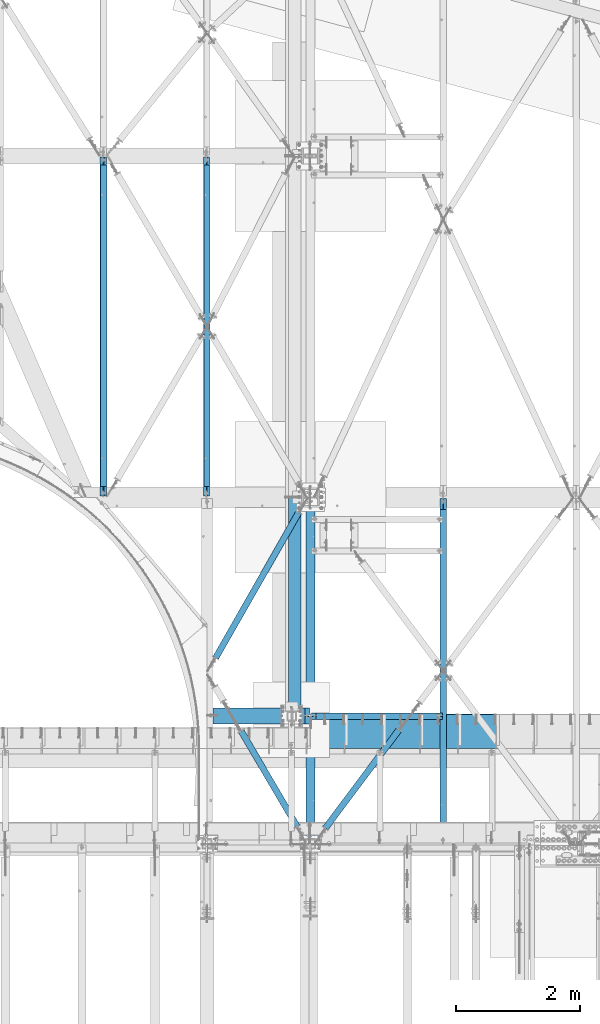
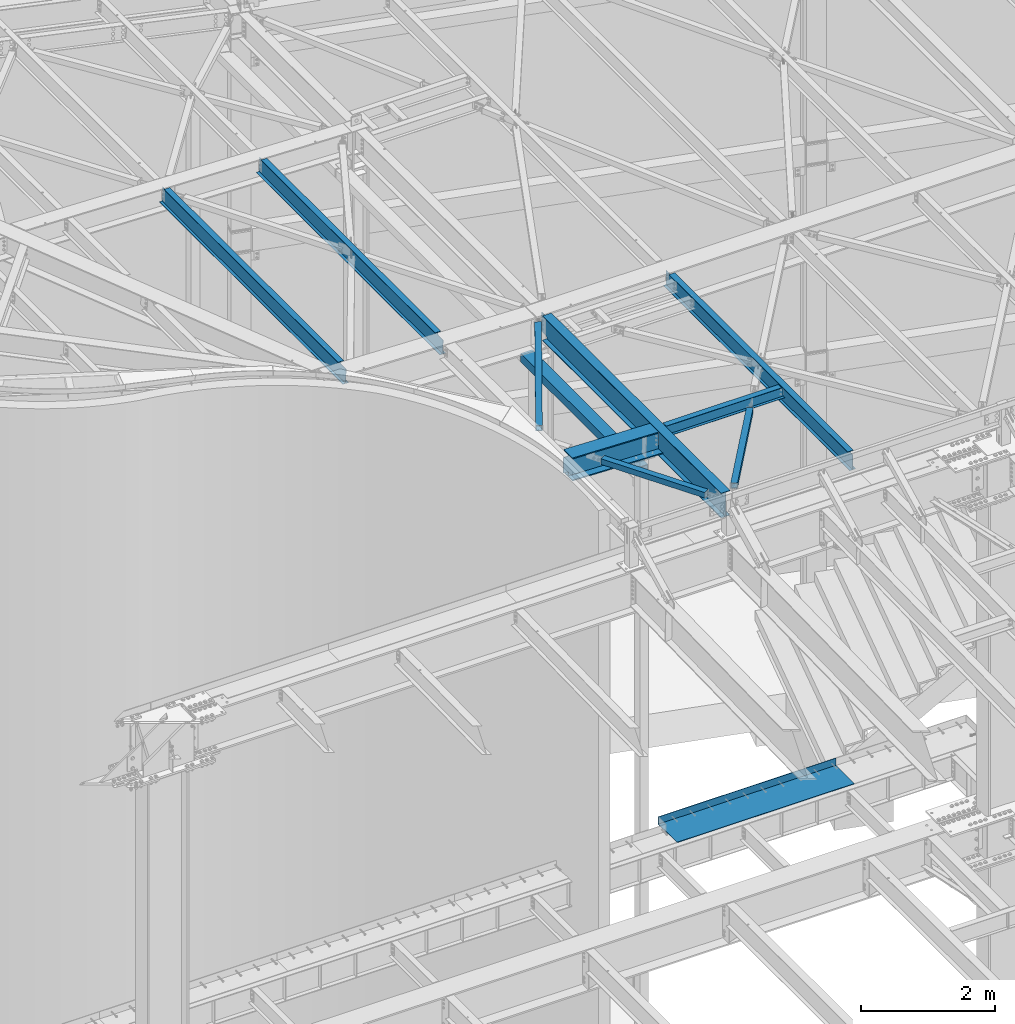
# One storey, part 1150 of 1763: 11 beams, 11 elements without a shape of their own.
"""IFC2X3 building model written with IfcOpenShell, lengths in millimetres."""

from ifc_helpers import new_model, si_unit, frame, origin_with_axes, place, context, subcontext, project, spatial, faceted_brep, material, type_object, element, aggregate, save


model = new_model("IFC2X3")

# Units and contexts
model_context = context("Model", 3, precision=1e-05, world=origin_with_axes())
body_context = subcontext(model_context, "Body", "Model", "MODEL_VIEW")
ifc_project = project(units=[si_unit("LENGTHUNIT", "METRE", prefix="MILLI"), si_unit("AREAUNIT", "SQUARE_METRE"), si_unit("VOLUMEUNIT", "CUBIC_METRE"), si_unit("MASSUNIT", "GRAM", prefix="KILO"), si_unit("TIMEUNIT", "SECOND"), si_unit("PLANEANGLEUNIT", "RADIAN"), si_unit("SOLIDANGLEUNIT", "STERADIAN"), si_unit("THERMODYNAMICTEMPERATUREUNIT", "DEGREE_CELSIUS"), si_unit("LUMINOUSINTENSITYUNIT", "LUMEN")], contexts=[model_context])

# Site, building, storey
site_placement = place(None, origin_with_axes())
site = spatial("IfcSite", under=ifc_project, at=site_placement, CompositionType="ELEMENT")
building_placement = place(site_placement, origin_with_axes())
building = spatial("IfcBuilding", under=site, at=building_placement, Name="Undefined", CompositionType="ELEMENT")
storey_placement = place(building_placement, origin_with_axes())
storey = spatial("IfcBuildingStorey", under=building, at=storey_placement, Name="Undefined", CompositionType="ELEMENT", Elevation=0.0)

# Assembly, beam
assembly_1_placement = place(storey_placement, origin_with_axes())
assembly_1 = element("IfcElementAssembly", 1, at=assembly_1_placement, inside=storey, Name="BEAM", AssemblyPlace="NOTDEFINED", PredefinedType="RIGID_FRAME")
ifc_material_1 = material(Name="STEEL/A992")
beam_type_1 = type_object("IfcBeamType", Name="W8X10", PredefinedType="NOTDEFINED")
beam_1_placement = place(assembly_1_placement, frame((-39672.2896175026, 54178.1999999993, 12345.9875), z_axis=(0.0, 0.0, 1.0), x_axis=(1.0, 0.0, 0.0)))
beam_1 = element("IfcBeam", 2, at=beam_1_placement, type_object=beam_type_1, material=ifc_material_1, Name="BEAM", ObjectType="W8X10", context=body_context, shape_type="Brep", body=[
    faceted_brep([(16.6687500075204, -2.38124999999854, -95.25), (16.6687500075204, -50.8000000000029, -95.25), (2124.075, -50.8000000000029, -95.25), (2124.075, -2.38124999999854, -95.25), (16.6687500075204, -50.8000000000029, -100.012500000001), (2124.075, -50.8000000000029, -100.012500000001), (16.6687500075204, 50.8000000000029, -100.012500000001), (2124.075, 50.8000000000029, -100.012500000001), (16.6687500075204, 50.8000000000029, -95.25), (2124.075, 50.8000000000029, -95.25), (2073.27499999999, -50.8000000000029, 100.012500000001), (2073.27499999999, -50.8000000000029, 95.25), (2073.27499999999, -2.38124999999854, 95.25), (2073.27499999999, -2.38124999999854, 93.4024995803829), (2073.27499999999, 2.38124999999854, 93.4024995803829), (2073.27499999999, 2.38124999999854, 95.25), (2073.27499999999, 50.8000000000029, 95.25), (2073.27499999999, 50.8000000000029, 100.012500000001), (2074.24172992259, -2.38124999999854, 88.5424200623365), (2074.24172992259, 2.38124999999854, 88.5424200623365), (2076.99474382306, -2.38124999999854, 84.4222435941829), (2076.99474382306, 2.38124999999854, 84.4222435941829), (2081.11492029121, -2.38124999999854, 81.6692296937053), (2081.11492029121, 2.38124999999854, 81.6692296937053), (2085.97499980926, -2.38124999999854, 80.7024997711178), (2085.97499980926, 2.38124999999854, 80.7024997711178), (2124.075, -2.38124999999854, 80.7024997711178), (2124.075, 2.38124999999854, 80.7024997711178), (2124.075, 2.38124999999854, -95.25), (16.6687500075204, 2.38124999999854, -95.25), (81.0600766645366, -2.38124999999854, 72.4042299225875), (81.0600766645366, 2.38124999999854, 72.4042299225875), (76.1999971464902, 2.38124999999854, 71.4375), (76.1999971464902, -2.38124999999854, 71.4375), (85.1802531326903, -2.38124999999854, 75.1572438230651), (85.1802531326903, 2.38124999999854, 75.1572438230651), (87.9332670331642, -2.38124999999854, 79.2774202912187), (87.9332670331642, 2.38124999999854, 79.2774202912187), (88.8999969557553, -2.38124999999854, 84.1374998092651), (88.8999969557553, 2.38124999999854, 84.1374998092651), (16.6687500075204, 2.38124999999854, 71.4375), (88.8999969557553, 2.38124999999854, 95.25), (88.8999969557553, 50.8000000000029, 95.25), (88.8999969557553, 50.8000000000029, 100.012500000001), (88.8999969557553, -50.8000000000029, 100.012500000001), (88.8999969557553, -50.8000000000029, 95.25), (88.8999969557553, -2.38124999999854, 95.25), (16.6687500075204, -2.38124999999854, 71.4375)], [[[0, 1, 2, 3]], [[1, 4, 5, 2]], [[4, 6, 7, 5]], [[6, 8, 9, 7]], [[10, 11, 12, 13, 14, 15, 16, 17]], [[18, 19, 14, 13]], [[20, 21, 19, 18]], [[22, 23, 21, 20]], [[24, 25, 23, 22]], [[26, 27, 25, 24]], [[3, 2, 5, 7, 9, 28, 27, 26]], [[8, 29, 28, 9]], [[30, 31, 32, 33]], [[34, 35, 31, 30]], [[36, 37, 35, 34]], [[38, 39, 37, 36]], [[28, 29, 40, 32, 31, 35, 37, 39, 41, 15, 14, 19, 21, 23, 25, 27]], [[41, 42, 16, 15]], [[42, 43, 17, 16]], [[43, 44, 10, 17]], [[44, 45, 11, 10]], [[45, 46, 12, 11]], [[44, 43, 42, 41, 39, 38, 46, 45]], [[22, 20, 18, 13, 12, 46, 38, 36, 34, 30, 33, 47, 0, 3, 26, 24]], [[29, 8, 6, 4, 1, 0, 47, 40]], [[33, 32, 40, 47]]]),
])
aggregate(assembly_1, [beam_1])

assembly_2_placement = place(storey_placement, origin_with_axes())
assembly_2 = element("IfcElementAssembly", 3, at=assembly_2_placement, inside=storey, Name="H. BRACE", AssemblyPlace="NOTDEFINED", PredefinedType="RIGID_FRAME")
ifc_material_2 = material()
beam_type_2 = type_object("IfcBeamType", Name="HSS4X4X3/8", PredefinedType="NOTDEFINED")
beam_2_placement = place(assembly_2_placement, frame((-38124.1466139279, 54121.0499999993, 12371.3875), z_axis=(0.0, 0.0, 1.0), x_axis=(-0.599271154042197, -0.800546116056367, 0.0)))
beam_2 = element("IfcBeam", 4, at=beam_2_placement, type_object=beam_type_2, material=ifc_material_2, Name="H. BRACE", ObjectType="HSS4X4X3/8", context=body_context, shape_type="Brep", body=[
    faceted_brep([(207.817612758732, 41.2749999996595, -41.2749999999996), (207.817612758732, -41.2750000005763, -41.2749999999996), (2179.99701835294, -41.2750000049418, -41.2749999999996), (2179.99701835295, 41.2749999952939, -41.2749999999996), (207.817612758732, -41.2750000005763, 41.2749999999996), (2179.99701835294, -41.2750000049418, 41.2749999999996), (207.817612758732, 41.2749999996595, 41.2749999999996), (2179.99701835295, 41.2749999952939, 41.2749999999996), (207.817612758736, 50.7999999996828, -50.7999999999993), (207.817612758736, 50.7999999996828, 50.7999999999993), (2179.99701835294, 50.7999999953317, 50.7999999999993), (2179.99701835294, 50.7999999953317, -50.7999999999993), (207.817612758729, -50.8000000005995, 50.7999999999993), (2179.99701835294, -50.8000000049651, 50.7999999999993), (207.817612758729, -50.8000000005995, -50.7999999999993), (2179.99701835294, -50.8000000049651, -50.7999999999993)], [[[0, 1, 2, 3]], [[1, 4, 5, 2]], [[4, 6, 7, 5]], [[6, 0, 3, 7]], [[8, 9, 10, 11]], [[9, 12, 13, 10]], [[12, 14, 15, 13]], [[14, 8, 11, 15]], [[13, 15, 11, 10], [5, 7, 3, 2]], [[14, 12, 9, 8], [6, 4, 1, 0]]]),
])
aggregate(assembly_2, [beam_2])

assembly_3_placement = place(storey_placement, origin_with_axes())
assembly_3 = element("IfcElementAssembly", 5, at=assembly_3_placement, inside=storey, Name="H. BRACE", AssemblyPlace="NOTDEFINED", PredefinedType="RIGID_FRAME")
beam_3_placement = place(assembly_3_placement, frame((-39723.0896174477, 52120.7999999996, 12371.3874999998), z_axis=(0.0, 0.0, 1.0), x_axis=(-0.506135019889158, 0.862454254811118, 0.0)))
beam_3 = element("IfcBeam", 6, at=beam_3_placement, type_object=beam_type_2, material=ifc_material_2, Name="H. BRACE", ObjectType="HSS4X4X3/8", context=body_context, shape_type="Brep", body=[
    faceted_brep([(326.409237413129, 41.2749999995231, -41.2749999999996), (326.409237413136, -41.2750000006035, -41.2749999999996), (2102.46857836019, -41.2750000035321, -41.2749999999996), (2102.46857836324, 41.2749999965836, -41.2749999999996), (326.409237413136, -41.2750000006035, 41.2749999999996), (2102.46857837139, -41.2750000035321, 41.2749999999996), (326.409237413129, 41.2749999995231, 41.2749999999996), (2102.46857837446, 41.2749999965836, 41.2749999999996), (326.409237413136, 50.7999999995282, -50.7999999999993), (326.409237413136, 50.7999999995282, 50.7999999999993), (2102.46857837609, 50.7999999965996, 50.7999999999993), (2102.46857836231, 50.7999999965996, -50.7999999999993), (326.409237413129, -50.8000000006086, 50.7999999999993), (2102.46857837234, -50.8000000035518, 50.7999999999993), (326.409237413129, -50.8000000006086, -50.7999999999993), (2102.46857835854, -50.8000000035518, -50.7999999999993)], [[[0, 1, 2, 3]], [[1, 4, 5, 2]], [[4, 6, 7, 5]], [[6, 0, 3, 7]], [[8, 9, 10, 11]], [[9, 12, 13, 10]], [[12, 14, 15, 13]], [[14, 8, 11, 15]], [[13, 15, 11, 10], [5, 7, 3, 2]], [[14, 12, 9, 8], [6, 4, 1, 0]]]),
])
aggregate(assembly_3, [beam_3])

assembly_4_placement = place(storey_placement, origin_with_axes())
assembly_4 = element("IfcElementAssembly", 7, at=assembly_4_placement, inside=storey, Name="H. BRACE", AssemblyPlace="NOTDEFINED", PredefinedType="RIGID_FRAME")
beam_4_placement = place(assembly_4_placement, frame((-39723.089617434, 57702.4500000121, 12371.3875), z_axis=(0.0, 0.0, 1.0), x_axis=(-0.495889007142934, -0.868385912250305, 0.0)))
beam_4 = element("IfcBeam", 8, at=beam_4_placement, type_object=beam_type_2, material=ifc_material_2, Name="H. BRACE", ObjectType="HSS4X4X3/8", context=body_context, shape_type="Brep", body=[
    faceted_brep([(285.423960958, 41.2750000006272, -41.2749999999996), (285.423960958004, -41.2749999996304, -41.2749999999996), (2975.4343394475, -41.2749999949665, -41.2749999999996), (2975.4343394475, 41.2750000052838, -41.2749999999996), (285.423960958004, -41.2749999996304, 41.2749999999996), (2975.4343394475, -41.2749999949665, 41.2749999999996), (285.423960958, 41.2750000006272, 41.2749999999996), (2975.4343394475, 41.2750000052838, 41.2749999999996), (285.423960958007, 50.8000000006505, -50.7999999999993), (285.423960958007, 50.8000000006505, 50.7999999999993), (2975.43433944751, 50.8000000053216, 50.7999999999993), (2975.43433944751, 50.8000000053216, -50.7999999999993), (285.423960958004, -50.7999999996609, 50.7999999999993), (2975.43433944751, -50.7999999950043, 50.7999999999993), (285.423960958004, -50.7999999996609, -50.7999999999993), (2975.43433944751, -50.7999999950043, -50.7999999999993)], [[[0, 1, 2, 3]], [[1, 4, 5, 2]], [[4, 6, 7, 5]], [[6, 0, 3, 7]], [[8, 9, 10, 11]], [[9, 12, 13, 10]], [[12, 14, 15, 13]], [[14, 8, 11, 15]], [[13, 15, 11, 10], [5, 7, 3, 2]], [[14, 12, 9, 8], [6, 4, 1, 0]]]),
])
aggregate(assembly_4, [beam_4])

assembly_5_placement = place(storey_placement, origin_with_axes())
assembly_5 = element("IfcElementAssembly", 9, at=assembly_5_placement, inside=storey, Name="BEAM", AssemblyPlace="NOTDEFINED", PredefinedType="RIGID_FRAME")
ifc_material_3 = material(Name="STEEL/A36")
beam_type_3 = type_object("IfcBeamType", PredefinedType="NOTDEFINED")
beam_5_placement = place(assembly_5_placement, frame((-38148.2896174484, 53657.5, 5199.0625), z_axis=(1.0, 0.0, 0.0), x_axis=(0.0, 1.0, 0.0)))
beam_5 = element("IfcBeam", 10, at=beam_5_placement, type_object=beam_type_3, material=ifc_material_3, Name="BENT PLATE", context=body_context, shape_type="Brep", body=[
    faceted_brep([(0.0, -4.76249999999982, -1524.0), (0.0, -4.76249999999982, 1524.0), (0.0, 4.76249999999982, 1524.0), (0.0, 4.76249999999982, -1524.0), (546.100000000006, 4.76249999999982, 1524.0), (546.100000000006, 4.76249999999982, -1524.0), (555.625, -4.76249999999982, -1524.0), (555.625, -4.76249999999982, 1524.0), (546.100000000006, 134.937496948242, 1524.0), (546.100000000006, 134.937496948242, -1524.0), (555.625, 134.937496948242, 1524.0), (555.625, 134.937496948242, -1524.0)], [[[0, 1, 2, 3]], [[3, 2, 4, 5]], [[1, 0, 6, 7]], [[5, 4, 8, 9]], [[4, 2, 1, 7, 10, 8]], [[7, 6, 11, 10]], [[6, 0, 3, 5, 9, 11]], [[10, 11, 9, 8]]]),
])
aggregate(assembly_5, [beam_5])

assembly_6_placement = place(storey_placement, origin_with_axes())
assembly_6 = element("IfcElementAssembly", 11, at=assembly_6_placement, inside=storey, Name="BEAM", AssemblyPlace="NOTDEFINED", PredefinedType="RIGID_FRAME")
beam_type_4 = type_object("IfcBeamType", Name="W12X16", PredefinedType="NOTDEFINED")
beam_6_placement = place(assembly_6_placement, frame((-43008.8652893648, 57702.45, 12391.7005364318), z_axis=(0.0294363099980619, 0.0, 0.999566657934176), x_axis=(0.0, 1.0, 0.0)))
beam_6 = element("IfcBeam", 12, at=beam_6_placement, type_object=beam_type_4, material=ifc_material_1, Name="BEAM", ObjectType="W12X16", context=body_context, shape_type="Brep", body=[
    faceted_brep([(20.637499999335, -3.17500000023574, -146.050000000019), (20.637499999335, -50.8000000002503, -146.05000000003), (5480.84374999933, -50.8000000002503, -146.05000000003), (5480.84374999933, -3.17500000023574, -146.050000000019), (20.637499999335, -50.8000000002576, -152.400000000032), (5480.84374999933, -50.8000000002576, -152.400000000032), (20.637499999335, 50.7999999997701, -152.400000000003), (5480.84374999933, 50.7999999997701, -152.400000000003), (20.637499999335, 50.7999999997774, -146.050000000005), (5480.84374999933, 50.7999999997774, -146.050000000005), (5356.22500610327, -50.7999999997846, 152.400000000001), (5356.22500610327, -50.7999999997919, 146.050000000003), (5356.22500610327, -3.17499999978463, 146.050000000016), (5356.22500610327, -3.17499999981374, 125.285104586563), (5356.22500610327, 3.17500000018481, 125.285104586579), (5356.22500610327, 3.17500000022119, 146.050000000017), (5356.22500610327, 50.8000000002285, 146.05000000003), (5356.22500610327, 50.8000000002357, 152.400000000032), (5357.19173602586, -3.17499999982101, 120.425025068516), (5357.19173602586, 3.17500000017753, 120.425025068527), (5359.94474992633, -3.17499999982829, 116.304848600361), (5359.94474992633, 3.17500000017026, 116.304848600375), (5364.06492639449, -3.17499999983556, 113.551834699883), (5364.06492639449, 3.17500000016298, 113.551834699894), (5368.92500591253, -3.17499999983556, 112.585104777294), (5368.92500591253, 3.17500000016298, 112.585104777307), (5480.84374999933, -3.17499999983556, 112.585104777085), (5480.84374999933, 3.17500000016298, 112.585104777076), (5480.84374999933, 3.17499999977008, -146.050000000016), (20.637499999335, 3.17499999977008, -146.050000000016), (168.372576656366, -3.17499999985012, 103.511779606619), (168.372576656366, 3.17500000014843, 103.511779606633), (163.512497138319, 3.17500000014843, 102.545049684046), (163.512497138319, -3.17499999985012, 102.545049684031), (172.492753124519, -3.17499999985012, 106.2647935071), (172.492753124519, 3.17500000015571, 106.264793507111), (175.245767024993, -3.17499999983556, 110.384969975255), (175.245767024993, 3.17500000016298, 110.384969975266), (176.212496947584, -3.17499999982829, 115.245049493302), (176.212496947584, 3.17500000017026, 115.245049493313), (20.637499999335, 3.17500000014843, 102.545049684255), (176.212496947584, 3.17500000022119, 146.050000000017), (176.212496947584, 50.8000000002285, 146.05000000003), (176.212496947584, 50.8000000002357, 152.400000000032), (176.212496947584, -50.7999999997846, 152.400000000001), (176.212496947584, -50.7999999997919, 146.050000000003), (176.212496947584, -3.17499999978463, 146.050000000016), (20.637499999335, -3.17499999985012, 102.545049684262)], [[[0, 1, 2, 3]], [[1, 4, 5, 2]], [[4, 6, 7, 5]], [[6, 8, 9, 7]], [[10, 11, 12, 13, 14, 15, 16, 17]], [[18, 19, 14, 13]], [[20, 21, 19, 18]], [[22, 23, 21, 20]], [[24, 25, 23, 22]], [[26, 27, 25, 24]], [[3, 2, 5, 7, 9, 28, 27, 26]], [[8, 29, 28, 9]], [[30, 31, 32, 33]], [[34, 35, 31, 30]], [[36, 37, 35, 34]], [[38, 39, 37, 36]], [[15, 14, 19, 21, 23, 25, 27, 28, 29, 40, 32, 31, 35, 37, 39, 41]], [[16, 15, 41, 42]], [[17, 16, 42, 43]], [[10, 17, 43, 44]], [[11, 10, 44, 45]], [[12, 11, 45, 46]], [[44, 43, 42, 41, 39, 38, 46, 45]], [[36, 34, 30, 33, 47, 0, 3, 26, 24, 22, 20, 18, 13, 12, 46, 38]], [[29, 8, 6, 4, 1, 0, 47, 40]], [[33, 32, 40, 47]]]),
])
aggregate(assembly_6, [beam_6])

assembly_7_placement = place(storey_placement, origin_with_axes())
assembly_7 = element("IfcElementAssembly", 13, at=assembly_7_placement, inside=storey, Name="BEAM", AssemblyPlace="NOTDEFINED", PredefinedType="RIGID_FRAME")
beam_7_placement = place(assembly_7_placement, frame((-41343.024315424, 57702.4500000225, 12342.6801043308), z_axis=(0.0294363099980619, 0.0, 0.999566657934176), x_axis=(0.0, 1.0, 0.0)))
beam_7 = element("IfcBeam", 14, at=beam_7_placement, type_object=beam_type_4, material=ifc_material_1, Name="BEAM", ObjectType="W12X16", context=body_context, shape_type="Brep", body=[
    faceted_brep([(20.637499999335, -3.17500000023574, -146.050000000019), (20.637499999335, -50.8000000002503, -146.05000000003), (5480.84374999933, -50.8000000002503, -146.05000000003), (5480.84374999933, -3.17500000023574, -146.050000000019), (20.637499999335, -50.8000000002576, -152.400000000032), (5480.84374999933, -50.8000000002576, -152.400000000032), (20.637499999335, 50.7999999997701, -152.400000000003), (5480.84374999933, 50.7999999997701, -152.400000000003), (20.637499999335, 50.7999999997774, -146.050000000005), (5480.84374999933, 50.7999999997774, -146.050000000005), (5356.22500610327, -50.7999999997846, 152.400000000001), (5356.22500610327, -50.7999999997919, 146.050000000003), (5356.22500610327, -3.17499999978463, 146.050000000016), (5356.22500608081, -3.17499999981374, 122.97482751928), (5356.22500608081, 3.17500000018481, 122.974827519292), (5356.22500610327, 3.17500000022119, 146.050000000017), (5356.22500610327, 50.8000000002285, 146.05000000003), (5356.22500610327, 50.8000000002357, 152.400000000032), (5357.1917360034, -3.17499999982101, 118.114748001233), (5357.1917360034, 3.17500000017753, 118.114748001244), (5359.94474990387, -3.17499999982829, 113.994571533076), (5359.94474990387, 3.17500000017753, 113.994571533092), (5364.06492637203, -3.17499999983556, 111.241557632598), (5364.06492637203, 3.17500000017026, 111.241557632609), (5368.92500589007, -3.17499999983556, 110.274827710011), (5368.92500589007, 3.17500000016298, 110.274827710022), (5480.84374997687, -3.17499999983556, 110.274827709802), (5480.84374997687, 3.17500000016298, 110.274827709791), (5480.84374999933, 3.17499999977008, -146.050000000016), (20.637499999335, 3.17499999977008, -146.050000000016), (168.372576633905, -3.17499999985012, 101.258135918861), (168.372576633905, 3.17500000014843, 101.258135918875), (163.512497115858, 3.17500000014843, 100.291405996286), (163.512497115858, -3.17499999985012, 100.291405996273), (172.492753102058, -3.17499999984284, 104.01114981934), (172.492753102058, 3.17500000015571, 104.011149819355), (175.245767002532, -3.17499999983556, 108.131326287496), (175.245767002532, 3.17500000016298, 108.131326287508), (176.212496925124, -3.17499999983556, 112.991405805542), (176.212496925124, 3.17500000017753, 112.991405805555), (20.6374999768741, 3.17500000014843, 100.291405996495), (176.212496947584, 3.17500000022119, 146.050000000017), (176.212496947584, 50.8000000002285, 146.05000000003), (176.212496947584, 50.8000000002357, 152.400000000032), (176.212496947584, -50.7999999997846, 152.400000000001), (176.212496947584, -50.7999999997919, 146.050000000003), (176.212496947584, -3.17499999978463, 146.050000000016), (20.6374999768741, -3.17499999985012, 100.291405996506)], [[[0, 1, 2, 3]], [[1, 4, 5, 2]], [[4, 6, 7, 5]], [[6, 8, 9, 7]], [[10, 11, 12, 13, 14, 15, 16, 17]], [[18, 19, 14, 13]], [[20, 21, 19, 18]], [[22, 23, 21, 20]], [[24, 25, 23, 22]], [[26, 27, 25, 24]], [[3, 2, 5, 7, 9, 28, 27, 26]], [[8, 29, 28, 9]], [[30, 31, 32, 33]], [[34, 35, 31, 30]], [[36, 37, 35, 34]], [[38, 39, 37, 36]], [[15, 14, 19, 21, 23, 25, 27, 28, 29, 40, 32, 31, 35, 37, 39, 41]], [[16, 15, 41, 42]], [[17, 16, 42, 43]], [[10, 17, 43, 44]], [[11, 10, 44, 45]], [[12, 11, 45, 46]], [[44, 43, 42, 41, 39, 38, 46, 45]], [[36, 34, 30, 33, 47, 0, 3, 26, 24, 22, 20, 18, 13, 12, 46, 38]], [[29, 8, 6, 4, 1, 0, 47, 40]], [[33, 32, 40, 47]]]),
])
aggregate(assembly_7, [beam_7])

assembly_8_placement = place(storey_placement, origin_with_axes())
assembly_8 = element("IfcElementAssembly", 15, at=assembly_8_placement, inside=storey, Name="BEAM", AssemblyPlace="NOTDEFINED", PredefinedType="RIGID_FRAME")
beam_8_placement = place(assembly_8_placement, frame((-37532.3396174484, 52120.8, 12293.6), z_axis=(0.0, 0.0, 1.0), x_axis=(0.0, 1.0, 0.0)))
beam_8 = element("IfcBeam", 16, at=beam_8_placement, type_object=beam_type_4, material=ifc_material_1, Name="BEAM", ObjectType="W12X16", context=body_context, shape_type="Brep", body=[
    faceted_brep([(63.5000001907174, -3.17499999999927, 126.740001678467), (63.5000001907174, 3.17499999999927, 126.740001678467), (15.8749999999854, 3.17499999999927, 126.740001678467), (15.8749999999854, -3.17499999999927, 126.740001678467), (68.3600797087638, -3.17499999999927, 127.706731601054), (68.3600797087638, 3.17499999999927, 127.706731601054), (72.4802561769175, -3.17499999999927, 130.459745501532), (72.4802561769175, 3.17499999999927, 130.459745501532), (75.2332700773914, -3.17499999999927, 134.579921969686), (75.2332700773914, 3.17499999999927, 134.579921969686), (76.1999999999825, -3.17499999999927, 139.440001487732), (76.1999999999825, 3.17499999999927, 139.440001487732), (76.1999999999825, -50.7999999999993, 152.4), (76.1999999999825, 50.7999999999993, 152.4), (76.1999999999825, 50.7999999999993, 146.049999999999), (76.1999999999825, 3.17499999999927, 146.049999999999), (76.1999999999825, -3.17499999999927, 146.049999999999), (76.1999999999825, -50.7999999999993, 146.049999999999), (15.8749999999854, -3.17499999999927, -146.049999999999), (15.8749999999854, -50.7999999999993, -146.049999999999), (5561.01249999999, -50.7999999999993, -146.049999999999), (5561.01249999999, -3.17499999999927, -146.049999999999), (15.8749999999854, -50.7999999999993, -152.4), (5561.01249999999, -50.7999999999993, -152.4), (15.8749999999854, 50.7999999999993, -152.4), (5561.01249999999, 50.7999999999993, -152.4), (15.8749999999854, 50.7999999999993, -146.049999999999), (5561.01249999999, 50.7999999999993, -146.049999999999), (15.8749999999854, 3.17499999999927, -146.049999999999), (5561.01249999999, 3.17499999999927, -146.049999999999), (5561.01249999999, 3.17499999999927, 114.040001678466), (5561.01249999999, -3.17499999999927, 114.040001678466), (5402.26249980926, 3.17499999999927, 114.040001678466), (5402.26249980926, -3.17499999999927, 114.040001678466), (5397.40242029121, 3.17499999999927, 115.006731601054), (5397.40242029121, -3.17499999999927, 115.006731601054), (5393.28224382306, 3.17499999999927, 117.759745501531), (5393.28224382306, -3.17499999999927, 117.759745501531), (5390.52922992258, 3.17499999999927, 121.879921969685), (5390.52922992258, -3.17499999999927, 121.879921969685), (5389.56249999999, 3.17499999999927, 126.740001487731), (5389.56249999999, -3.17499999999927, 126.740001487731), (5389.56249999999, -50.7999999999993, 152.4), (5389.56249999999, -50.7999999999993, 146.049999999999), (5389.56249999999, -3.17499999999927, 146.049999999999), (5389.56249999999, 3.17499999999927, 146.049999999999), (5389.56249999999, 50.7999999999993, 146.049999999999), (5389.56249999999, 50.7999999999993, 152.4)], [[[0, 1, 2, 3]], [[4, 5, 1, 0]], [[6, 7, 5, 4]], [[8, 9, 7, 6]], [[10, 11, 9, 8]], [[12, 13, 14, 15, 11, 10, 16, 17]], [[18, 19, 20, 21]], [[19, 22, 23, 20]], [[22, 24, 25, 23]], [[24, 26, 27, 25]], [[26, 28, 29, 27]], [[21, 20, 23, 25, 27, 29, 30, 31]], [[31, 30, 32, 33]], [[33, 32, 34, 35]], [[35, 34, 36, 37]], [[37, 36, 38, 39]], [[39, 38, 40, 41]], [[42, 43, 44, 41, 40, 45, 46, 47]], [[43, 42, 12, 17]], [[44, 43, 17, 16]], [[8, 6, 4, 0, 3, 18, 21, 31, 33, 35, 37, 39, 41, 44, 16, 10]], [[28, 26, 24, 22, 19, 18, 3, 2]], [[45, 40, 38, 36, 34, 32, 30, 29, 28, 2, 1, 5, 7, 9, 11, 15]], [[46, 45, 15, 14]], [[47, 46, 14, 13]], [[42, 47, 13, 12]]]),
])
aggregate(assembly_8, [beam_8])

assembly_9_placement = place(storey_placement, origin_with_axes())
assembly_9 = element("IfcElementAssembly", 17, at=assembly_9_placement, inside=storey, Name="BEAM", AssemblyPlace="NOTDEFINED", PredefinedType="RIGID_FRAME")
beam_type_5 = type_object("IfcBeamType", Name="W18X35", PredefinedType="NOTDEFINED")
beam_9_placement = place(assembly_9_placement, frame((-39672.2896174408, 52044.6000000031, 12220.575), z_axis=(0.0, 0.0, 1.0), x_axis=(0.0, 1.0, 0.0)))
beam_9 = element("IfcBeam", 18, at=beam_9_placement, type_object=beam_type_5, material=ifc_material_1, Name="BEAM", ObjectType="W18X35", context=body_context, shape_type="Brep", body=[
    faceted_brep([(5637.2124999969, -3.96875, 174.365001678467), (5637.2124999969, 3.96875, 174.365001678467), (5491.16249980615, 3.96875, 174.365001678467), (5491.16249980615, -3.96875, 174.365001678467), (5486.3024202881, 3.96875, 175.331731601054), (5486.3024202881, -3.96875, 175.331731601054), (5482.18224381995, 3.96875, 178.084745501532), (5482.18224381995, -3.96875, 178.084745501532), (5479.42922991946, 3.96875, 182.204921969686), (5479.42922991946, -3.96875, 182.204921969686), (5478.46249999688, 3.96875, 187.065001487732), (5478.46249999688, -3.96875, 187.065001487732), (165.09999999791, -76.1999999999971, 214.3125), (165.09999999791, -3.96875, 214.3125), (5478.46249999688, -3.96875, 214.3125), (5478.46249999688, -76.1999999999971, 214.3125), (165.09999999791, -76.1999999999971, 225.424999999999), (5478.46249999688, -76.1999999999971, 225.424999999999), (165.09999999791, 76.1999999999971, 225.424999999999), (5478.46249999688, 76.1999999999971, 225.424999999999), (165.09999999791, 76.1999999999971, 214.3125), (5478.46249999688, 76.1999999999971, 214.3125), (5478.46249999688, 3.96875, 214.3125), (165.09999999791, 3.96875, 214.3125), (165.09999999791, -76.1999999999971, -225.424999999999), (165.09999999791, -76.1999999999971, -214.3125), (165.09999999791, -3.96875, -214.3125), (165.09999999791, 3.96875, -214.3125), (165.09999999791, 76.1999999999971, -214.3125), (165.09999999791, 76.1999999999971, -225.424999999999), (5478.46249999688, 3.96875, -214.3125), (5478.46249999688, 76.1999999999971, -214.3125), (5478.46249999688, 76.1999999999971, -225.424999999999), (5478.46249999688, -76.1999999999971, -225.424999999999), (5478.46249999688, -76.1999999999971, -214.3125), (5478.46249999688, -3.96875, -214.3125), (5478.46249999688, -3.96875, -187.584999809265), (5479.42922991946, -3.96875, -182.724920291219), (5482.18224381995, -3.96875, -178.604743823065), (5486.3024202881, -3.96875, -175.851729922588), (5491.16249980615, -3.96875, -174.885), (5637.2124999969, -3.96875, -174.885), (5637.2124999969, 3.96875, -174.885), (5486.3024202881, 3.96875, -175.851729922588), (5482.18224381995, 3.96875, -178.604743823065), (5479.42922991946, 3.96875, -182.724920291219), (5478.46249999688, 3.96875, -187.584999809265), (5491.16249980615, 3.96875, -174.885)], [[[0, 1, 2, 3]], [[3, 2, 4, 5]], [[5, 4, 6, 7]], [[7, 6, 8, 9]], [[9, 8, 10, 11]], [[12, 13, 14, 15]], [[16, 12, 15, 17]], [[18, 16, 17, 19]], [[20, 18, 19, 21]], [[17, 15, 14, 11, 10, 22, 21, 19]], [[23, 20, 21, 22]], [[24, 25, 26, 13, 12, 16, 18, 20, 23, 27, 28, 29]], [[28, 27, 30, 31]], [[29, 28, 31, 32]], [[24, 29, 32, 33]], [[25, 24, 33, 34]], [[26, 25, 34, 35]], [[0, 3, 5, 7, 9, 11, 14, 13, 26, 35, 36, 37, 38, 39, 40, 41]], [[1, 0, 41, 42]], [[43, 44, 45, 46, 30, 27, 23, 22, 10, 8, 6, 4, 2, 1, 42, 47]], [[41, 40, 47, 42]], [[39, 43, 47, 40]], [[38, 44, 43, 39]], [[37, 45, 44, 38]], [[36, 46, 45, 37]], [[35, 34, 33, 32, 31, 30, 46, 36]]]),
])
aggregate(assembly_9, [beam_9])

assembly_10_placement = place(storey_placement, origin_with_axes())
assembly_10 = element("IfcElementAssembly", 19, at=assembly_10_placement, inside=storey, Name="BEAM", AssemblyPlace="NOTDEFINED", PredefinedType="RIGID_FRAME")
beam_type_6 = type_object("IfcBeamType", Name="HSS8X6X3/8", PredefinedType="NOTDEFINED")
beam_10_placement = place(assembly_10_placement, frame((-39926.2896174484, 54254.4, 11684.0), z_axis=(-1.0, 0.0, 0.0), x_axis=(0.0, 1.0, 0.0)))
beam_10 = element("IfcBeam", 20, at=beam_10_placement, type_object=beam_type_6, material=ifc_material_2, Name="BEAM", ObjectType="HSS8X6X3/8", context=body_context, shape_type="Brep", body=[
    faceted_brep([(1.58750000000146, 66.6749999999993, -92.0749999999971), (1.58750000000146, -66.6749999999993, -92.0749999999971), (3438.52499999999, -66.6749999999993, -92.0749999999971), (3438.52499999999, 66.6749999999993, -92.0749999999971), (1.58750000000146, -66.6749999999993, 92.0749999999971), (3438.52499999999, -66.6749999999993, 92.0749999999971), (1.58750000000146, 66.6749999999993, 92.0749999999971), (3438.52499999999, 66.6749999999993, 92.0749999999971), (1.58750000000146, 76.2000000000007, -101.599999999999), (1.58750000000146, 76.2000000000007, 101.599999999999), (3438.52499999999, 76.2000000000007, 101.599999999999), (3438.52499999999, 76.2000000000007, -101.599999999999), (1.58750000000146, -76.2000000000007, 101.599999999999), (3438.52499999999, -76.2000000000007, 101.599999999999), (1.58750000000146, -76.2000000000007, -101.599999999999), (3438.52499999999, -76.2000000000007, -101.599999999999)], [[[0, 1, 2, 3]], [[1, 4, 5, 2]], [[4, 6, 7, 5]], [[6, 0, 3, 7]], [[8, 9, 10, 11]], [[9, 12, 13, 10]], [[12, 14, 15, 13]], [[14, 8, 11, 15]], [[13, 15, 11, 10], [5, 7, 3, 2]], [[14, 12, 9, 8], [6, 4, 1, 0]]]),
])
aggregate(assembly_10, [beam_10])

assembly_11_placement = place(storey_placement, origin_with_axes())
assembly_11 = element("IfcElementAssembly", 21, at=assembly_11_placement, inside=storey, Name="BEAM", AssemblyPlace="NOTDEFINED", PredefinedType="RIGID_FRAME")
beam_type_7 = type_object("IfcBeamType", Name="W16X77", PredefinedType="NOTDEFINED")
beam_11_placement = place(assembly_11_placement, frame((-41344.9737827026, 54178.1999999993, 12287.7457206592), z_axis=(0.0307113389869774, 0.0, 0.999528295576282), x_axis=(0.999528295576282, 0.0, -0.0307113389869804)))
beam_11 = element("IfcBeam", 22, at=beam_11_placement, type_object=beam_type_7, material=ifc_material_1, Name="BEAM", ObjectType="W16X77", context=body_context, shape_type="Brep", body=[
    faceted_brep([(25.8804157485283, -5.55625000000146, -115.841478375685), (25.8804157485283, 5.55625000000146, -115.841478375685), (95.6974704365712, 5.55625000000146, -113.69629124783), (95.6974704365712, -5.55625000000146, -113.69629124783), (100.58494700399, 5.55625000000146, -114.513305610055), (100.58494700399, -5.55625000000146, -114.513305610055), (104.787728709838, 5.55625000000146, -117.138484765501), (104.787728709838, -5.55625000000146, -117.138484765501), (107.665980137695, 5.55625000000146, -121.172168985058), (107.665980137695, -5.55625000000146, -121.172168985058), (108.781513599082, 5.55625000000146, -126.00026641174), (108.781513599082, -5.55625000000146, -126.00026641174), (111.348648718587, -130.175000000003, -209.550000000054), (110.763321609498, -130.175000000003, -190.500000000042), (110.763321609498, -5.55625000000146, -190.500000000042), (110.763321609498, 5.55625000000146, -190.500000000042), (110.763321609498, 130.175000000003, -190.500000000042), (111.348648718587, 130.175000000003, -209.550000000054), (1578.6783278497, -130.175000000003, 190.500000001332), (1578.09300074061, -130.175000000003, 209.550000001344), (98.471452318423, -130.175000000003, 209.550000000212), (99.0567794275121, -130.175000000003, 190.500000000202), (1578.09300074061, 130.175000000003, 209.550000001344), (98.471452318423, 130.175000000003, 209.550000000212), (1578.6783278497, 130.175000000003, 190.500000001332), (99.0567794275121, 130.175000000003, 190.500000000202), (1578.6783278497, 5.55625000000146, 190.500000001332), (99.0567794275121, 5.55625000000146, 190.500000000202), (87.0334837015616, -5.55625000000146, 168.280990746236), (87.0334837015616, 5.55625000000146, 168.280990746236), (17.2164290136934, 5.55625000000146, 166.135803618386), (17.2164290136934, -5.55625000000146, 166.135803618386), (91.861581128258, -5.55625000000146, 169.396524207625), (91.861581128258, 5.55625000000146, 169.396524207625), (95.8952653478336, -5.55625000000146, 172.274775635473), (95.8952653478336, 5.55625000000146, 172.274775635473), (98.5204445032941, -5.55625000000146, 176.477557341297), (98.5204445032941, 5.55625000000146, 176.477557341297), (99.3374588655133, -5.55625000000146, 181.365033908703), (99.3374588655133, 5.55625000000146, 181.365033908703), (99.0567794275121, -5.55625000000146, 190.500000000202), (1578.6783278497, -5.55625000000146, 190.500000001332), (1578.98297552622, -5.55625000000146, 180.58496591601), (1578.98297552622, 5.55625000000146, 180.58496591601), (1580.0985089876, -5.55625000000146, 175.756868489327), (1580.0985089876, 5.55625000000146, 175.756868489327), (1582.97676041546, -5.55625000000146, 171.723184269769), (1582.97676041546, 5.55625000000146, 171.723184269769), (1587.1795421213, -5.55625000000146, 169.098005114323), (1587.1795421213, 5.55625000000146, 169.098005114323), (1592.06701868873, -5.55625000000146, 168.280990752097), (1592.06701868873, 5.55625000000146, 168.280990752097), (1651.57018462094, -5.55625000000146, 170.109275061637), (1651.57018462094, 5.55625000000146, 170.109275061637), (1662.65020480373, -5.55625000000146, -190.499999998858), (1662.65020480373, -130.175000000003, -190.499999998858), (1663.23553191282, -130.175000000003, -209.54999999887), (1663.23553191282, 130.175000000003, -209.54999999887), (1662.65020480373, 130.175000000003, -190.499999998858), (1662.65020480373, 5.55625000000146, -190.499999998858)], [[[0, 1, 2, 3]], [[3, 2, 4, 5]], [[5, 4, 6, 7]], [[7, 6, 8, 9]], [[9, 8, 10, 11]], [[12, 13, 14, 11, 10, 15, 16, 17]], [[18, 19, 20, 21]], [[19, 22, 23, 20]], [[22, 24, 25, 23]], [[24, 26, 27, 25]], [[28, 29, 30, 31]], [[32, 33, 29, 28]], [[34, 35, 33, 32]], [[36, 37, 35, 34]], [[38, 39, 37, 36]], [[40, 21, 20, 23, 25, 27, 39, 38]], [[41, 18, 21, 40]], [[42, 43, 26, 24, 22, 19, 18, 41]], [[44, 45, 43, 42]], [[46, 47, 45, 44]], [[48, 49, 47, 46]], [[50, 51, 49, 48]], [[52, 53, 51, 50]], [[54, 55, 56, 57, 58, 59, 53, 52]], [[57, 56, 12, 17]], [[58, 57, 17, 16]], [[59, 58, 16, 15]], [[8, 6, 4, 2, 1, 30, 29, 33, 35, 37, 39, 27, 26, 43, 45, 47, 49, 51, 53, 59, 15, 10]], [[31, 30, 1, 0]], [[54, 52, 50, 48, 46, 44, 42, 41, 40, 38, 36, 34, 32, 28, 31, 0, 3, 5, 7, 9, 11, 14]], [[55, 54, 14, 13]], [[56, 55, 13, 12]]]),
])
aggregate(assembly_11, [beam_11])

save(model, "model.ifc")
